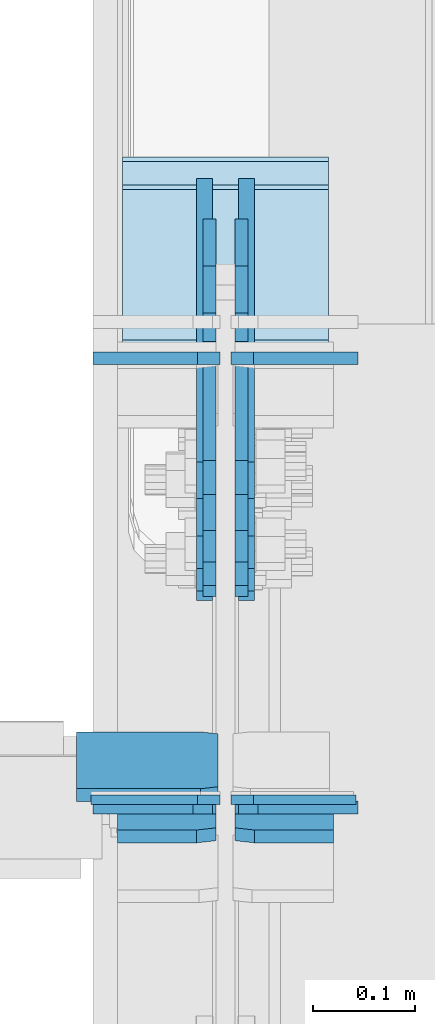
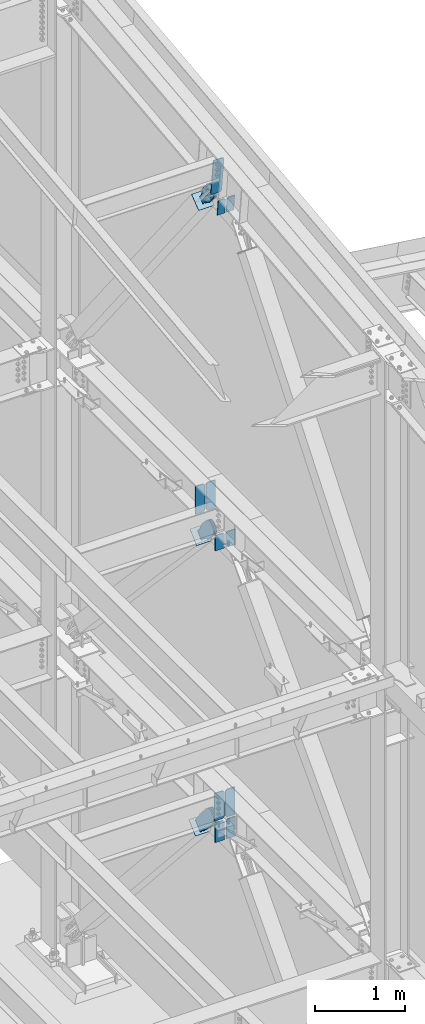
# One storey, part 1049 of 1179: 20 plates, 12 elements without a shape of their own.
"""IFC2X3 building model written with IfcOpenShell, lengths in millimetres."""

from ifc_helpers import new_model, si_unit, frame, origin_with_axes, place, context, subcontext, project, spatial, faceted_brep, material, type_object, element, aggregate, save


model = new_model("IFC2X3")

# Units and contexts
model_context = context("Model", 3, precision=1e-05, world=origin_with_axes())
body_context = subcontext(model_context, "Body", "Model", "MODEL_VIEW")
ifc_project = project(units=[si_unit("LENGTHUNIT", "METRE", prefix="MILLI"), si_unit("AREAUNIT", "SQUARE_METRE"), si_unit("VOLUMEUNIT", "CUBIC_METRE"), si_unit("MASSUNIT", "GRAM", prefix="KILO"), si_unit("TIMEUNIT", "SECOND"), si_unit("PLANEANGLEUNIT", "RADIAN"), si_unit("SOLIDANGLEUNIT", "STERADIAN"), si_unit("THERMODYNAMICTEMPERATUREUNIT", "DEGREE_CELSIUS"), si_unit("LUMINOUSINTENSITYUNIT", "LUMEN")], contexts=[model_context])

# Site, building, storey
site_placement = place(None, origin_with_axes())
site = spatial("IfcSite", under=ifc_project, at=site_placement, CompositionType="ELEMENT")
building_placement = place(site_placement, origin_with_axes())
building = spatial("IfcBuilding", under=site, at=building_placement, Name="Undefined", CompositionType="ELEMENT")
storey_placement = place(building_placement, origin_with_axes())
storey = spatial("IfcBuildingStorey", under=building, at=storey_placement, Name="Undefined", CompositionType="ELEMENT", Elevation=0.0)

# Assembly, plate
assembly_1_placement = place(storey_placement, origin_with_axes())
assembly_1 = element("IfcElementAssembly", 1, at=assembly_1_placement, inside=storey, Name="BEAM", AssemblyPlace="NOTDEFINED", PredefinedType="RIGID_FRAME")
ifc_material_1 = material(Name="STEEL/A572-GR.50")
plate_type_1 = type_object("IfcPlateType", PredefinedType="NOTDEFINED")
plate_1_placement = place(assembly_1_placement, frame((24302.24375, 30729.2375, 3703.6375), z_axis=(0.0, 0.0, 1.0), x_axis=(-1.0, 0.0, 0.0)))
plate_1 = element("IfcPlate", 2, at=plate_1_placement, type_object=plate_type_1, material=ifc_material_1, Name="PLATE", context=body_context, shape_type="Brep", body=[
    faceted_brep([(0.0, -4.76250000000073, 22.2250003814697), (0.0, -4.76249999999709, 355.600011825562), (0.0, 4.76249999999709, 355.600011825562), (0.0, 4.76250000000073, 22.2250003814697), (22.2250003814697, -4.76249999999709, 377.825012207031), (22.2250003814697, 4.76249999999709, 377.825012207031), (127.0, -4.76249999999709, 377.825), (127.0, 4.76249999999709, 377.825), (127.0, -4.76250000000073, 0.0), (127.0, 4.76250000000073, 0.0), (22.2250003814697, -4.76250000000073, 0.0), (22.2250003814697, 4.76250000000073, 0.0)], [[[0, 1, 2, 3]], [[1, 4, 5, 2]], [[4, 6, 7, 5]], [[6, 8, 9, 7]], [[8, 10, 11, 9]], [[10, 0, 3, 11]], [[5, 7, 9, 11, 3, 2]], [[10, 8, 6, 4, 1, 0]]]),
])

assembly_2_placement = place(storey_placement, origin_with_axes())
assembly_2 = element("IfcElementAssembly", 3, at=assembly_2_placement, inside=storey, Name="BEAM", AssemblyPlace="NOTDEFINED", PredefinedType="RIGID_FRAME")
ifc_material_2 = material(Name="STEEL/A36")
plate_type_2 = type_object("IfcPlateType", PredefinedType="NOTDEFINED")
plate_2_placement = place(assembly_2_placement, frame((24300.65625, 30733.6261163401, 12694.1774782498), z_axis=(-1.0, 0.0, 0.0), x_axis=(0.0, 0.112284087038014, -0.993676146336441)))
plate_2 = element("IfcPlate", 4, at=plate_2_placement, type_object=plate_type_2, material=ifc_material_2, Name="PLATE", context=body_context, shape_type="Brep", body=[
    faceted_brep([(0.0, -6.34999999998763, 17.4624996185248), (0.0, -6.34999999999673, 139.700000000001), (-3.63797880709171e-12, 6.34999999999491, 139.700000000001), (0.0, 6.35000000000582, 17.4624996185175), (498.474999999775, -6.34999999979482, 139.700000000001), (498.474999999769, 6.35000000019681, 139.700000000001), (498.474999999775, -6.34999999979482, 17.4624996185303), (498.474999999769, 6.35000000019681, 17.4624996185303), (481.012500381255, -6.34999999980209, 0.0), (481.01250038125, 6.35000000019136, 0.0), (17.4624996185303, -6.34999999999309, 1.81898940354586e-12), (17.4624996185303, 6.34999999999854, -1.81898940354586e-12)], [[[0, 1, 2, 3]], [[1, 4, 5, 2]], [[4, 6, 7, 5]], [[6, 8, 9, 7]], [[8, 10, 11, 9]], [[10, 0, 3, 11]], [[5, 7, 9, 11, 3, 2]], [[10, 8, 6, 4, 1, 0]]]),
])

# Assembly, plates
assembly_3_placement = place(storey_placement, origin_with_axes())
assembly_3 = element("IfcElementAssembly", 5, at=assembly_3_placement, inside=storey, Name="BEAM", AssemblyPlace="NOTDEFINED", PredefinedType="RIGID_FRAME")
plate_type_3 = type_object("IfcPlateType", PredefinedType="NOTDEFINED")
plate_3_placement = place(assembly_3_placement, frame((24298.275, 30721.3, 7594.6000000002), z_axis=(-1.0, 0.0, 0.0), x_axis=(0.0, 0.0, -1.0)))
plate_3 = element("IfcPlate", 6, at=plate_3_placement, type_object=plate_type_3, material=ifc_material_1, Name="PLATE", context=body_context, shape_type="Brep", body=[
    faceted_brep([(0.0, 6.35000000000036, 19.0499999999993), (19.0500000000002, 6.35000000000036, 0.0), (19.0500000000002, -6.35000000000036, 0.0), (0.0, -6.35000000000036, 19.0499999999993), (0.0, -6.34999999999854, 120.650000000001), (0.0, 6.34999999999854, 120.650000000001), (210.124280632681, -6.34999999999854, 120.649999999998), (210.124280632681, 6.34999999999854, 120.649999999998), (210.124280632681, -6.34999999999854, 0.0), (210.124280632681, 6.34999999999854, 0.0)], [[[0, 1, 2, 3]], [[4, 5, 0, 3]], [[4, 6, 7, 5]], [[6, 8, 9, 7]], [[9, 8, 2, 1]], [[5, 7, 9, 1, 0]], [[8, 6, 4, 3, 2]]]),
])
plate_4_placement = place(assembly_3_placement, frame((24317.325, 30721.3, 7594.6000000002), z_axis=(1.0, 0.0, 0.0), x_axis=(0.0, 0.0, -1.0)))
plate_4 = element("IfcPlate", 7, at=plate_4_placement, type_object=plate_type_3, material=ifc_material_1, Name="PLATE", context=body_context, shape_type="Brep", body=[
    faceted_brep([(0.0, 6.35000000000036, 19.0499999999993), (19.0500000000002, 6.35000000000036, 0.0), (19.0500000000002, -6.35000000000036, 0.0), (0.0, -6.35000000000036, 19.0499999999993), (0.0, -6.34999999999854, 120.650000000001), (0.0, 6.34999999999854, 120.650000000001), (210.124280632681, -6.34999999999854, 120.649999999998), (210.124280632681, 6.34999999999854, 120.649999999998), (210.124280632681, -6.34999999999854, 0.0), (210.124280632681, 6.34999999999854, 0.0)], [[[0, 1, 2, 3]], [[4, 5, 0, 3]], [[4, 6, 7, 5]], [[6, 8, 9, 7]], [[9, 8, 2, 1]], [[5, 7, 9, 1, 0]], [[8, 6, 4, 3, 2]]]),
])

# Assembly, plate
assembly_4_placement = place(storey_placement, origin_with_axes())
assembly_4 = element("IfcElementAssembly", 8, at=assembly_4_placement, inside=storey, AssemblyPlace="NOTDEFINED", PredefinedType="RIGID_FRAME")
plate_type_4 = type_object("IfcPlateType", PredefinedType="NOTDEFINED")
plate_5_placement = place(assembly_4_placement, frame((24291.925, 31208.0431244763, 11900.7203215671), z_axis=(0.0, -0.784153429306135, -0.620566998242276), x_axis=(0.0, 0.620566998242269, -0.78415342930614)))
plate_5 = element("IfcPlate", 9, at=plate_5_placement, type_object=plate_type_4, material=ifc_material_2, context=body_context, shape_type="Brep", body=[
    faceted_brep([(0.0, -6.34999999999854, 0.0), (-101.600000000211, -6.34999999999854, -44.6881937825565), (-101.600000000211, 6.34999999999854, -44.6881937825565), (0.0, 6.34999999999854, 0.0), (-246.684985848258, -6.34999999999854, -44.6881937827675), (-246.684985848258, 6.34999999999854, -44.6881937827675), (-281.313054102191, -6.34999999999854, -37.800242748639), (-281.313054102191, 6.34999999999854, -37.800242748639), (-310.669312868691, -6.34999999999854, -18.1850177516608), (-310.669312868691, 6.34999999999854, -18.1850177516608), (-330.284537865713, -6.34999999999854, 11.1712410148393), (-330.284537865713, 6.34999999999854, 11.1712410148393), (-337.172488899912, -6.34999999999854, 45.7993031647638), (-337.172488899912, 6.34999999999854, 45.7993031647638), (-330.284537865768, -6.34999999999854, 80.4273714187839), (-330.284537865768, 6.34999999999854, 80.4273714187839), (-310.669312868773, -6.34999999999854, 109.783630185371), (-310.669312868773, 6.34999999999854, 109.783630185371), (-281.313054102271, -6.34999999999854, 129.398855182466), (-281.313054102271, 6.34999999999854, 129.398855182466), (-246.684988899762, -6.34999999999854, 136.286806216707), (-246.684988899762, 6.34999999999854, 136.286806216707), (-101.600000000377, -6.34999999999854, 136.286806216911), (-101.600000000377, 6.34999999999854, 136.286806216911), (-8.18545231595635e-11, -6.34999999999854, 91.5986124346418), (-8.18545231595635e-11, 6.34999999999854, 91.5986124346418), (74.9300000003022, -6.34999999999854, 91.5986124341325), (74.9300000003022, 6.34999999999854, 91.5986124341325), (74.9300000005605, -6.34999999999854, 6.91215973347425e-11), (74.9300000005605, 6.34999999999854, 6.91215973347425e-11)], [[[0, 1, 2, 3]], [[1, 4, 5, 2]], [[4, 6, 7, 5]], [[6, 8, 9, 7]], [[8, 10, 11, 9]], [[10, 12, 13, 11]], [[12, 14, 15, 13]], [[14, 16, 17, 15]], [[16, 18, 19, 17]], [[18, 20, 21, 19]], [[20, 22, 23, 21]], [[22, 24, 25, 23]], [[24, 26, 27, 25]], [[26, 28, 29, 27]], [[28, 0, 3, 29]], [[5, 7, 9, 11, 13, 15, 17, 19, 21, 23, 25, 27, 29, 3, 2]], [[28, 26, 24, 22, 20, 18, 16, 14, 12, 10, 8, 6, 4, 1, 0]]]),
])
aggregate(assembly_4, [plate_5])

assembly_5_placement = place(storey_placement, origin_with_axes())
assembly_5 = element("IfcElementAssembly", 10, at=assembly_5_placement, inside=storey, AssemblyPlace="NOTDEFINED", PredefinedType="RIGID_FRAME")
plate_6_placement = place(assembly_5_placement, frame((24323.675, 31208.0431244763, 11900.7203215671), z_axis=(0.0, -0.784153429306135, -0.620566998242276), x_axis=(0.0, 0.620566998242269, -0.78415342930614)))
plate_6 = element("IfcPlate", 11, at=plate_6_placement, type_object=plate_type_4, material=ifc_material_2, context=body_context, shape_type="Brep", body=[
    faceted_brep([(0.0, -6.34999999999854, 0.0), (-101.600000000211, -6.34999999999854, -44.6881937825565), (-101.600000000211, 6.34999999999854, -44.6881937825565), (0.0, 6.34999999999854, 0.0), (-246.684985848258, -6.34999999999854, -44.6881937827675), (-246.684985848258, 6.34999999999854, -44.6881937827675), (-281.313054102191, -6.34999999999854, -37.800242748639), (-281.313054102191, 6.34999999999854, -37.800242748639), (-310.669312868691, -6.34999999999854, -18.1850177516608), (-310.669312868691, 6.34999999999854, -18.1850177516608), (-330.284537865713, -6.34999999999854, 11.1712410148393), (-330.284537865713, 6.34999999999854, 11.1712410148393), (-337.172488899912, -6.34999999999854, 45.7993031647638), (-337.172488899912, 6.34999999999854, 45.7993031647638), (-330.284537865768, -6.34999999999854, 80.4273714187839), (-330.284537865768, 6.34999999999854, 80.4273714187839), (-310.669312868773, -6.34999999999854, 109.783630185371), (-310.669312868773, 6.34999999999854, 109.783630185371), (-281.313054102271, -6.34999999999854, 129.398855182466), (-281.313054102271, 6.34999999999854, 129.398855182466), (-246.684988899762, -6.34999999999854, 136.286806216707), (-246.684988899762, 6.34999999999854, 136.286806216707), (-101.600000000377, -6.34999999999854, 136.286806216911), (-101.600000000377, 6.34999999999854, 136.286806216911), (-8.18545231595635e-11, -6.34999999999854, 91.5986124346418), (-8.18545231595635e-11, 6.34999999999854, 91.5986124346418), (74.9300000003022, -6.34999999999854, 91.5986124341325), (74.9300000003022, 6.34999999999854, 91.5986124341325), (74.9300000005605, -6.34999999999854, 6.91215973347425e-11), (74.9300000005605, 6.34999999999854, 6.91215973347425e-11)], [[[0, 1, 2, 3]], [[1, 4, 5, 2]], [[4, 6, 7, 5]], [[6, 8, 9, 7]], [[8, 10, 11, 9]], [[10, 12, 13, 11]], [[12, 14, 15, 13]], [[14, 16, 17, 15]], [[16, 18, 19, 17]], [[18, 20, 21, 19]], [[20, 22, 23, 21]], [[22, 24, 25, 23]], [[24, 26, 27, 25]], [[26, 28, 29, 27]], [[28, 0, 3, 29]], [[5, 7, 9, 11, 13, 15, 17, 19, 21, 23, 25, 27, 29, 3, 2]], [[28, 26, 24, 22, 20, 18, 16, 14, 12, 10, 8, 6, 4, 1, 0]]]),
])
aggregate(assembly_5, [plate_6])

assembly_6_placement = place(storey_placement, origin_with_axes())
assembly_6 = element("IfcElementAssembly", 12, at=assembly_6_placement, inside=storey, Name="Plate", AssemblyPlace="NOTDEFINED", PredefinedType="RIGID_FRAME")
plate_type_5 = type_object("IfcPlateType", PredefinedType="NOTDEFINED")
plate_7_placement = place(assembly_6_placement, frame((24206.2, 31136.9882379974, 11752.9822472356), z_axis=(0.0, 0.784153429306134, 0.620566998242277), x_axis=(1.0, 0.0, 0.0)))
plate_7 = element("IfcPlate", 13, at=plate_7_placement, type_object=plate_type_5, material=ifc_material_2, Name="Plate", context=body_context, shape_type="Brep", body=[
    faceted_brep([(0.0, -3.17500000000109, 0.0), (0.0, -3.17500000000291, 203.200000000368), (0.0, 3.17499999998836, 203.200000000361), (0.0, 3.17500000000109, 7.27595761418343e-12), (203.199999999997, -3.17500000000291, 203.200000000368), (203.199999999997, 3.17499999998836, 203.200000000361), (203.199999999997, -3.17499999999927, 3.63797880709171e-12), (203.199999999997, 3.17499999999382, -3.63797880709171e-12)], [[[0, 1, 2, 3]], [[1, 4, 5, 2]], [[4, 6, 7, 5]], [[6, 0, 3, 7]], [[5, 7, 3, 2]], [[6, 4, 1, 0]]]),
])
aggregate(assembly_6, [plate_7])

assembly_7_placement = place(storey_placement, origin_with_axes())
assembly_7 = element("IfcElementAssembly", 14, at=assembly_7_placement, inside=storey, Name="Plate", AssemblyPlace="NOTDEFINED", PredefinedType="RIGID_FRAME")
plate_8_placement = place(assembly_7_placement, frame((24206.2, 31183.7164897806, 7162.85000805757), z_axis=(0.0, 0.729241792887681, 0.684256097894612), x_axis=(1.0, 0.0, 0.0)))
plate_8 = element("IfcPlate", 15, at=plate_8_placement, type_object=plate_type_5, material=ifc_material_2, Name="Plate", context=body_context, shape_type="Brep", body=[
    faceted_brep([(0.0, -3.17500000000109, 0.0), (0.0, -3.17500000000291, 203.200000000368), (0.0, 3.17499999998836, 203.200000000361), (0.0, 3.17500000000109, 7.27595761418343e-12), (203.199999999997, -3.17500000000291, 203.200000000368), (203.199999999997, 3.17499999998836, 203.200000000361), (203.199999999997, -3.17499999999927, 3.63797880709171e-12), (203.199999999997, 3.17499999999382, -3.63797880709171e-12)], [[[0, 1, 2, 3]], [[1, 4, 5, 2]], [[4, 6, 7, 5]], [[6, 0, 3, 7]], [[5, 7, 3, 2]], [[6, 4, 1, 0]]]),
])
aggregate(assembly_7, [plate_8])

assembly_8_placement = place(storey_placement, origin_with_axes())
assembly_8 = element("IfcElementAssembly", 16, at=assembly_8_placement, inside=storey, Name="Plate", AssemblyPlace="NOTDEFINED", PredefinedType="RIGID_FRAME")
plate_9_placement = place(assembly_8_placement, frame((24206.2, 31207.8863640126, 3195.37459362686), z_axis=(0.0, 0.745753571678113, 0.666221892712434), x_axis=(1.0, 0.0, 0.0)))
plate_9 = element("IfcPlate", 17, at=plate_9_placement, type_object=plate_type_5, material=ifc_material_2, Name="Plate", context=body_context, shape_type="Brep", body=[
    faceted_brep([(0.0, -3.17500000000109, 0.0), (0.0, -3.17500000000291, 203.200000000368), (0.0, 3.17499999998836, 203.200000000361), (0.0, 3.17500000000109, 7.27595761418343e-12), (203.199999999997, -3.17500000000291, 203.200000000368), (203.199999999997, 3.17499999998836, 203.200000000361), (203.199999999997, -3.17499999999927, 3.63797880709171e-12), (203.199999999997, 3.17499999999382, -3.63797880709171e-12)], [[[0, 1, 2, 3]], [[1, 4, 5, 2]], [[4, 6, 7, 5]], [[6, 0, 3, 7]], [[5, 7, 3, 2]], [[6, 4, 1, 0]]]),
])
aggregate(assembly_8, [plate_9])

# Plate
plate_type_6 = type_object("IfcPlateType", PredefinedType="NOTDEFINED")
plate_10_placement = place(assembly_2_placement, frame((24298.275, 30692.9808266493, 12162.37562255), z_axis=(-1.0, 0.0, 0.0), x_axis=(0.0, 0.112284087038014, -0.993676146336441)))
plate_10 = element("IfcPlate", 18, at=plate_10_placement, type_object=plate_type_6, material=ifc_material_1, Name="PLATE", context=body_context, shape_type="Brep", body=[
    faceted_brep([(0.0, 6.35000000000036, 19.0499999999993), (19.0500000000002, 6.35000000000036, 0.0), (19.0500000000002, -6.35000000000036, 0.0), (0.0, -6.35000000000036, 19.0499999999993), (0.0, -6.35000000000036, 96.8374999999978), (0.0, 6.35000000000036, 96.8374999999978), (215.455080662674, -6.3499999999076, 96.8375000000015), (215.45508066267, 6.35000000008222, 96.8375000000015), (215.455080662674, -6.3499999999076, 0.0), (215.45508066267, 6.35000000008222, 0.0)], [[[0, 1, 2, 3]], [[4, 5, 0, 3]], [[4, 6, 7, 5]], [[6, 8, 9, 7]], [[9, 8, 2, 1]], [[5, 7, 9, 1, 0]], [[8, 6, 4, 3, 2]]]),
])

plate_11_placement = place(assembly_2_placement, frame((24317.325, 30692.9808266493, 12162.37562255), z_axis=(1.0, 0.0, 0.0), x_axis=(0.0, 0.112284087038014, -0.993676146336441)))
plate_11 = element("IfcPlate", 19, at=plate_11_placement, type_object=plate_type_6, material=ifc_material_1, Name="PLATE", context=body_context, shape_type="Brep", body=[
    faceted_brep([(0.0, 6.35000000000036, 19.0499999999993), (19.0500000000002, 6.35000000000036, 0.0), (19.0500000000002, -6.35000000000036, 0.0), (0.0, -6.35000000000036, 19.0499999999993), (0.0, -6.35000000000036, 96.8374999999978), (0.0, 6.35000000000036, 96.8374999999978), (215.455080662674, -6.3499999999076, 96.8375000000015), (215.45508066267, 6.35000000008222, 96.8375000000015), (215.455080662674, -6.3499999999076, 0.0), (215.45508066267, 6.35000000008222, 0.0)], [[[0, 1, 2, 3]], [[4, 5, 0, 3]], [[4, 6, 7, 5]], [[6, 8, 9, 7]], [[9, 8, 2, 1]], [[5, 7, 9, 1, 0]], [[8, 6, 4, 3, 2]]]),
])

aggregate(assembly_2, [plate_10, plate_11, plate_2])

plate_type_7 = type_object("IfcPlateType", PredefinedType="NOTDEFINED")
plate_12_placement = place(assembly_3_placement, frame((24302.24375, 31163.6495595727, 7613.65), z_axis=(-1.0, 0.0, 0.0), x_axis=(0.0, 0.0, 1.0)))
plate_12 = element("IfcPlate", 20, at=plate_12_placement, type_object=plate_type_7, material=ifc_material_1, Name="PLATE", context=body_context, shape_type="Brep", body=[
    faceted_brep([(0.0, -6.34999999999854, 22.2250003814697), (0.0, -6.34999999999854, 124.618750000001), (0.0, 6.34999999999854, 124.618750000001), (0.0, 6.34999999999854, 22.2250003814697), (381.0, -6.34999999999854, 124.618750000001), (381.0, 6.34999999999854, 124.618750000001), (381.0, -6.34999999999854, 22.2250003814697), (381.0, 6.34999999999854, 22.2250003814697), (358.77499961853, -6.34999999999854, 0.0), (358.77499961853, 6.34999999999854, 0.0), (22.2250003814697, -6.34999999999854, 0.0), (22.2250003814697, 6.34999999999854, 0.0)], [[[0, 1, 2, 3]], [[1, 4, 5, 2]], [[4, 6, 7, 5]], [[6, 8, 9, 7]], [[8, 10, 11, 9]], [[10, 0, 3, 11]], [[5, 7, 9, 11, 3, 2]], [[10, 8, 6, 4, 1, 0]]]),
])

plate_13_placement = place(assembly_3_placement, frame((24313.35625, 31163.6495595727, 7613.65), z_axis=(1.0, 0.0, 0.0), x_axis=(0.0, 0.0, 1.0)))
plate_13 = element("IfcPlate", 21, at=plate_13_placement, type_object=plate_type_7, material=ifc_material_1, Name="PLATE", context=body_context, shape_type="Brep", body=[
    faceted_brep([(0.0, -6.34999999999854, 22.2250003814697), (0.0, -6.34999999999854, 124.618750000001), (0.0, 6.34999999999854, 124.618750000001), (0.0, 6.34999999999854, 22.2250003814697), (381.0, -6.34999999999854, 124.618750000001), (381.0, 6.34999999999854, 124.618750000001), (381.0, -6.34999999999854, 22.2250003814697), (381.0, 6.34999999999854, 22.2250003814697), (358.77499961853, -6.34999999999854, 0.0), (358.77499961853, 6.34999999999854, 0.0), (22.2250003814697, -6.34999999999854, 0.0), (22.2250003814697, 6.34999999999854, 0.0)], [[[0, 1, 2, 3]], [[1, 4, 5, 2]], [[4, 6, 7, 5]], [[6, 8, 9, 7]], [[8, 10, 11, 9]], [[10, 0, 3, 11]], [[5, 7, 9, 11, 3, 2]], [[10, 8, 6, 4, 1, 0]]]),
])

aggregate(assembly_3, [plate_12, plate_13, plate_3, plate_4])

plate_type_8 = type_object("IfcPlateType", PredefinedType="NOTDEFINED")
plate_14_placement = place(assembly_1_placement, frame((24295.1, 30721.3, 3414.03211161582), z_axis=(-1.0, 0.0, 0.0), x_axis=(0.0, 0.0, 1.0)))
plate_14 = element("IfcPlate", 22, at=plate_14_placement, type_object=plate_type_8, material=ifc_material_1, Name="PLATE", context=body_context, shape_type="Brep", body=[
    faceted_brep([(0.0, -6.34999999999854, 0.0), (0.0, -6.35000000000036, 117.474999999999), (0.0, 6.35000000000036, 117.474999999999), (0.0, 6.34999999999854, 0.0), (268.967888384181, -6.34999999964202, 117.475000000002), (268.967888384181, 6.3500000003587, 117.475000000002), (268.967888384181, -6.34999999964202, 19.0499992370605), (268.967888384181, 6.3500000003587, 19.0499992370605), (249.917889147121, -6.34999999966749, 0.0), (249.917889147121, 6.35000000033324, 0.0)], [[[0, 1, 2, 3]], [[1, 4, 5, 2]], [[4, 6, 7, 5]], [[6, 8, 9, 7]], [[8, 0, 3, 9]], [[5, 7, 9, 3, 2]], [[8, 6, 4, 1, 0]]]),
])

plate_15_placement = place(assembly_1_placement, frame((24320.5, 30721.3, 3414.03211161582), z_axis=(1.0, 0.0, 0.0), x_axis=(0.0, 0.0, 1.0)))
plate_15 = element("IfcPlate", 23, at=plate_15_placement, type_object=plate_type_8, material=ifc_material_1, Name="PLATE", context=body_context, shape_type="Brep", body=[
    faceted_brep([(0.0, -6.34999999999854, 0.0), (0.0, -6.35000000000036, 117.474999999999), (0.0, 6.35000000000036, 117.474999999999), (0.0, 6.34999999999854, 0.0), (268.967888384181, -6.34999999964202, 117.475000000002), (268.967888384181, 6.3500000003587, 117.475000000002), (268.967888384181, -6.34999999964202, 19.0499992370605), (268.967888384181, 6.3500000003587, 19.0499992370605), (249.917889147121, -6.34999999966749, 0.0), (249.917889147121, 6.35000000033324, 0.0)], [[[0, 1, 2, 3]], [[1, 4, 5, 2]], [[4, 6, 7, 5]], [[6, 8, 9, 7]], [[8, 0, 3, 9]], [[5, 7, 9, 3, 2]], [[8, 6, 4, 1, 0]]]),
])

# Assembly, plate
assembly_9_placement = place(storey_placement, origin_with_axes())
assembly_9 = element("IfcElementAssembly", 24, at=assembly_9_placement, inside=storey, AssemblyPlace="NOTDEFINED", PredefinedType="RIGID_FRAME")
plate_type_9 = type_object("IfcPlateType", PredefinedType="NOTDEFINED")
plate_16_placement = place(assembly_9_placement, frame((24291.925, 31244.399598217, 7328.63560640106), z_axis=(0.0, -0.729241792887679, -0.684256097894614), x_axis=(0.0, 0.684256097894613, -0.72924179288768)))
plate_16 = element("IfcPlate", 25, at=plate_16_placement, type_object=plate_type_9, material=ifc_material_2, context=body_context, shape_type="Brep", body=[
    faceted_brep([(0.0, -6.34999999999854, 0.0), (-101.599999999963, -6.34999999999854, -37.5700345970108), (-101.599999999963, 6.34999999999854, -37.5700345970108), (0.0, 6.34999999999854, 0.0), (-245.369242323884, -6.34999999999854, -37.5700345970945), (-245.369242323884, 6.34999999999854, -37.5700345970945), (-281.212328723803, -6.34999999999854, -30.4404014271258), (-281.212328723803, 6.34999999999854, -30.4404014271258), (-311.598630137756, -6.34999999999854, -10.1369239370142), (-311.598630137756, 6.34999999999854, -10.1369239370142), (-331.902107627997, -6.34999999999854, 20.24937747687), (-331.902107627997, 6.34999999999854, 20.24937747687), (-339.031740798124, -6.34999999999854, 56.0924669287269), (-339.031740798124, 6.34999999999854, 56.0924669287269), (-331.902107628228, -6.34999999999854, 91.9355533287926), (-331.902107628228, 6.34999999999854, 91.9355533287926), (-311.598630138099, -6.34999999999854, 122.321854742866), (-311.598630138099, 6.34999999999854, 122.321854742866), (-281.212328724136, -6.34999999999854, 142.625332233139), (-281.212328724136, 6.34999999999854, 142.625332233139), (-245.36924079839, -6.34999999999854, 149.754965403199), (-245.36924079839, 6.34999999999854, 149.754965403199), (-101.600000000685, -6.34999999999854, 149.75496540329), (-101.600000000685, 6.34999999999854, 149.75496540329), (-4.35647962149233e-10, -6.34999999999854, 112.184930806416), (-4.35647962149233e-10, 6.34999999999854, 112.184930806416), (82.5499999996491, -6.34999999999854, 112.184930806461), (82.5499999996491, 6.34999999999854, 112.184930806461), (82.550000000203, -6.34999999999854, 1.2732925824821e-10), (82.550000000203, 6.34999999999854, 1.2732925824821e-10)], [[[0, 1, 2, 3]], [[1, 4, 5, 2]], [[4, 6, 7, 5]], [[6, 8, 9, 7]], [[8, 10, 11, 9]], [[10, 12, 13, 11]], [[12, 14, 15, 13]], [[14, 16, 17, 15]], [[16, 18, 19, 17]], [[18, 20, 21, 19]], [[20, 22, 23, 21]], [[22, 24, 25, 23]], [[24, 26, 27, 25]], [[26, 28, 29, 27]], [[28, 0, 3, 29]], [[5, 7, 9, 11, 13, 15, 17, 19, 21, 23, 25, 27, 29, 3, 2]], [[28, 26, 24, 22, 20, 18, 16, 14, 12, 10, 8, 6, 4, 1, 0]]]),
])
aggregate(assembly_9, [plate_16])

assembly_10_placement = place(storey_placement, origin_with_axes())
assembly_10 = element("IfcElementAssembly", 26, at=assembly_10_placement, inside=storey, AssemblyPlace="NOTDEFINED", PredefinedType="RIGID_FRAME")
plate_17_placement = place(assembly_10_placement, frame((24323.675, 31244.399598217, 7328.63560640106), z_axis=(0.0, -0.729241792887679, -0.684256097894614), x_axis=(0.0, 0.684256097894613, -0.72924179288768)))
plate_17 = element("IfcPlate", 27, at=plate_17_placement, type_object=plate_type_9, material=ifc_material_2, context=body_context, shape_type="Brep", body=[
    faceted_brep([(0.0, -6.34999999999854, 0.0), (-101.599999999963, -6.34999999999854, -37.5700345970108), (-101.599999999963, 6.34999999999854, -37.5700345970108), (0.0, 6.34999999999854, 0.0), (-245.369242323884, -6.34999999999854, -37.5700345970945), (-245.369242323884, 6.34999999999854, -37.5700345970945), (-281.212328723803, -6.34999999999854, -30.4404014271258), (-281.212328723803, 6.34999999999854, -30.4404014271258), (-311.598630137756, -6.34999999999854, -10.1369239370142), (-311.598630137756, 6.34999999999854, -10.1369239370142), (-331.902107627997, -6.34999999999854, 20.24937747687), (-331.902107627997, 6.34999999999854, 20.24937747687), (-339.031740798124, -6.34999999999854, 56.0924669287269), (-339.031740798124, 6.34999999999854, 56.0924669287269), (-331.902107628228, -6.34999999999854, 91.9355533287926), (-331.902107628228, 6.34999999999854, 91.9355533287926), (-311.598630138099, -6.34999999999854, 122.321854742866), (-311.598630138099, 6.34999999999854, 122.321854742866), (-281.212328724136, -6.34999999999854, 142.625332233139), (-281.212328724136, 6.34999999999854, 142.625332233139), (-245.36924079839, -6.34999999999854, 149.754965403199), (-245.36924079839, 6.34999999999854, 149.754965403199), (-101.600000000685, -6.34999999999854, 149.75496540329), (-101.600000000685, 6.34999999999854, 149.75496540329), (-4.35647962149233e-10, -6.34999999999854, 112.184930806416), (-4.35647962149233e-10, 6.34999999999854, 112.184930806416), (82.5499999996491, -6.34999999999854, 112.184930806461), (82.5499999996491, 6.34999999999854, 112.184930806461), (82.550000000203, -6.34999999999854, 1.2732925824821e-10), (82.550000000203, 6.34999999999854, 1.2732925824821e-10)], [[[0, 1, 2, 3]], [[1, 4, 5, 2]], [[4, 6, 7, 5]], [[6, 8, 9, 7]], [[8, 10, 11, 9]], [[10, 12, 13, 11]], [[12, 14, 15, 13]], [[14, 16, 17, 15]], [[16, 18, 19, 17]], [[18, 20, 21, 19]], [[20, 22, 23, 21]], [[22, 24, 25, 23]], [[24, 26, 27, 25]], [[26, 28, 29, 27]], [[28, 0, 3, 29]], [[5, 7, 9, 11, 13, 15, 17, 19, 21, 23, 25, 27, 29, 3, 2]], [[28, 26, 24, 22, 20, 18, 16, 14, 12, 10, 8, 6, 4, 1, 0]]]),
])
aggregate(assembly_10, [plate_17])

assembly_11_placement = place(storey_placement, origin_with_axes())
assembly_11 = element("IfcElementAssembly", 28, at=assembly_11_placement, inside=storey, AssemblyPlace="NOTDEFINED", PredefinedType="RIGID_FRAME")
plate_type_10 = type_object("IfcPlateType", PredefinedType="NOTDEFINED")
plate_18_placement = place(assembly_11_placement, frame((24287.1625, 31288.9353760447, 3367.40410992426), z_axis=(0.0, -0.74575357167811, -0.666221892712438), x_axis=(0.0, 0.666221892712438, -0.74575357167811)))
plate_18 = element("IfcPlate", 29, at=plate_18_placement, type_object=plate_type_10, material=ifc_material_2, context=body_context, shape_type="Brep", body=[
    faceted_brep([(0.0, -7.9375, 0.0), (-101.600000000497, -7.9375, -21.7975798445477), (-101.600000000497, 7.9375, -21.7975798445477), (0.0, 7.9375, 0.0), (-320.921138851689, -7.9375, -21.7975798443877), (-320.921138851689, 7.9375, -21.7975798443877), (-357.371735784433, -7.9375, -14.5471053160727), (-357.371735784433, 7.9375, -14.5471053160727), (-388.273059759649, -7.9375, 6.10049924760824), (-388.273059759649, 7.9375, 6.10049924760824), (-408.920664323319, -7.9375, 37.0018232228431), (-408.920664323319, 7.9375, 37.0018232228431), (-416.171138851623, -7.9375, 73.4524201546446), (-416.171138851623, 7.9375, 73.4524201546446), (-408.920664323337, -7.9375, 109.903017087447), (-408.920664323337, 7.9375, 109.903017087447), (-388.273059759656, -7.9375, 140.804341062707), (-388.273059759656, 7.9375, 140.804341062707), (-357.3717357844, -7.9375, 161.451945626395), (-357.3717357844, 7.9375, 161.451945626395), (-320.921138851201, -7.9375, 168.702420154674), (-320.921138851201, 7.9375, 168.702420154674), (-101.600000000592, -7.9375, 168.702420154521), (-101.600000000592, 7.9375, 168.702420154521), (-8.00355337560177e-11, -7.9375, 146.904840309817), (-8.00355337560177e-11, 7.9375, 146.904840309817), (77.4700000003613, -7.9375, 146.904840309813), (77.4700000003613, 7.9375, 146.904840309813), (77.4700000003904, -7.9375, -5.82076609134674e-11), (77.4700000003904, 7.9375, -5.82076609134674e-11)], [[[0, 1, 2, 3]], [[1, 4, 5, 2]], [[4, 6, 7, 5]], [[6, 8, 9, 7]], [[8, 10, 11, 9]], [[10, 12, 13, 11]], [[12, 14, 15, 13]], [[14, 16, 17, 15]], [[16, 18, 19, 17]], [[18, 20, 21, 19]], [[20, 22, 23, 21]], [[22, 24, 25, 23]], [[24, 26, 27, 25]], [[26, 28, 29, 27]], [[28, 0, 3, 29]], [[5, 7, 9, 11, 13, 15, 17, 19, 21, 23, 25, 27, 29, 3, 2]], [[28, 26, 24, 22, 20, 18, 16, 14, 12, 10, 8, 6, 4, 1, 0]]]),
])
aggregate(assembly_11, [plate_18])

assembly_12_placement = place(storey_placement, origin_with_axes())
assembly_12 = element("IfcElementAssembly", 30, at=assembly_12_placement, inside=storey, AssemblyPlace="NOTDEFINED", PredefinedType="RIGID_FRAME")
plate_19_placement = place(assembly_12_placement, frame((24328.4375, 31288.9353760447, 3367.40410992426), z_axis=(0.0, -0.74575357167811, -0.666221892712438), x_axis=(0.0, 0.666221892712438, -0.74575357167811)))
plate_19 = element("IfcPlate", 31, at=plate_19_placement, type_object=plate_type_10, material=ifc_material_2, context=body_context, shape_type="Brep", body=[
    faceted_brep([(0.0, -7.9375, 0.0), (-101.600000000497, -7.9375, -21.7975798445477), (-101.600000000497, 7.9375, -21.7975798445477), (0.0, 7.9375, 0.0), (-320.921138851689, -7.9375, -21.7975798443877), (-320.921138851689, 7.9375, -21.7975798443877), (-357.371735784433, -7.9375, -14.5471053160727), (-357.371735784433, 7.9375, -14.5471053160727), (-388.273059759649, -7.9375, 6.10049924760824), (-388.273059759649, 7.9375, 6.10049924760824), (-408.920664323319, -7.9375, 37.0018232228431), (-408.920664323319, 7.9375, 37.0018232228431), (-416.171138851623, -7.9375, 73.4524201546446), (-416.171138851623, 7.9375, 73.4524201546446), (-408.920664323337, -7.9375, 109.903017087447), (-408.920664323337, 7.9375, 109.903017087447), (-388.273059759656, -7.9375, 140.804341062707), (-388.273059759656, 7.9375, 140.804341062707), (-357.3717357844, -7.9375, 161.451945626395), (-357.3717357844, 7.9375, 161.451945626395), (-320.921138851201, -7.9375, 168.702420154674), (-320.921138851201, 7.9375, 168.702420154674), (-101.600000000592, -7.9375, 168.702420154521), (-101.600000000592, 7.9375, 168.702420154521), (-8.00355337560177e-11, -7.9375, 146.904840309817), (-8.00355337560177e-11, 7.9375, 146.904840309817), (77.4700000003613, -7.9375, 146.904840309813), (77.4700000003613, 7.9375, 146.904840309813), (77.4700000003904, -7.9375, -5.82076609134674e-11), (77.4700000003904, 7.9375, -5.82076609134674e-11)], [[[0, 1, 2, 3]], [[1, 4, 5, 2]], [[4, 6, 7, 5]], [[6, 8, 9, 7]], [[8, 10, 11, 9]], [[10, 12, 13, 11]], [[12, 14, 15, 13]], [[14, 16, 17, 15]], [[16, 18, 19, 17]], [[18, 20, 21, 19]], [[20, 22, 23, 21]], [[22, 24, 25, 23]], [[24, 26, 27, 25]], [[26, 28, 29, 27]], [[28, 0, 3, 29]], [[5, 7, 9, 11, 13, 15, 17, 19, 21, 23, 25, 27, 29, 3, 2]], [[28, 26, 24, 22, 20, 18, 16, 14, 12, 10, 8, 6, 4, 1, 0]]]),
])
aggregate(assembly_12, [plate_19])

# Plate
plate_type_11 = type_object("IfcPlateType", PredefinedType="NOTDEFINED")
plate_20_placement = place(assembly_1_placement, frame((24313.35625, 30729.2375, 3703.6375), z_axis=(0.0, 0.0, 1.0), x_axis=(1.0, 0.0, 0.0)))
plate_20 = element("IfcPlate", 32, at=plate_20_placement, type_object=plate_type_11, material=ifc_material_1, Name="PLATE", context=body_context, shape_type="Brep", body=[
    faceted_brep([(0.0, -4.76250000000073, 22.2250003814697), (0.0, -4.76249999999709, 355.600011825562), (0.0, 4.76249999999709, 355.600011825562), (0.0, 4.76250000000073, 22.2250003814697), (22.2250003814697, -4.76249999999709, 377.825012207031), (22.2250003814697, 4.76249999999709, 377.825012207031), (123.03125, -4.76250000000073, 377.825012207031), (123.03125, 4.76250000000073, 377.825012207031), (123.03125, -4.76250000000073, 0.0), (123.03125, 4.76250000000073, 0.0), (22.2250003814697, -4.76250000000073, 0.0), (22.2250003814697, 4.76250000000073, 0.0)], [[[0, 1, 2, 3]], [[1, 4, 5, 2]], [[4, 6, 7, 5]], [[6, 8, 9, 7]], [[8, 10, 11, 9]], [[10, 0, 3, 11]], [[5, 7, 9, 11, 3, 2]], [[10, 8, 6, 4, 1, 0]]]),
])

aggregate(assembly_1, [plate_14, plate_15, plate_20, plate_1])

save(model, "model.ifc")
